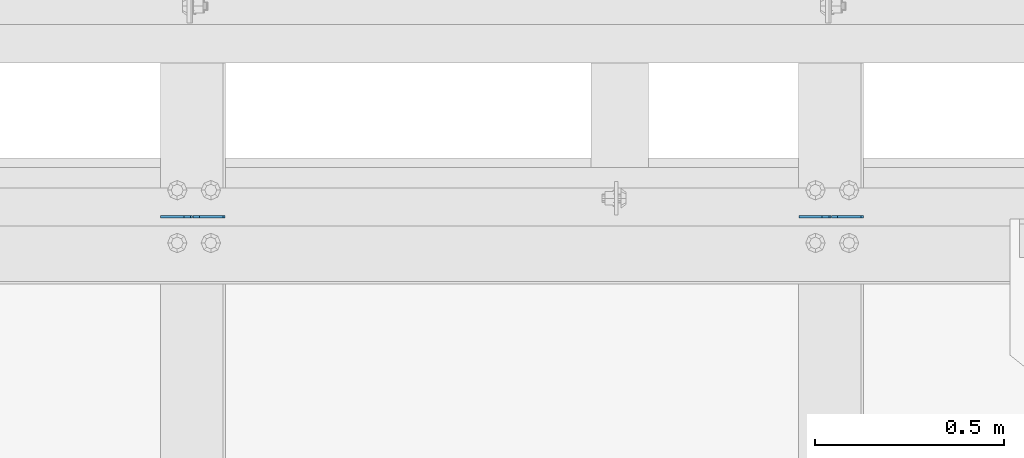
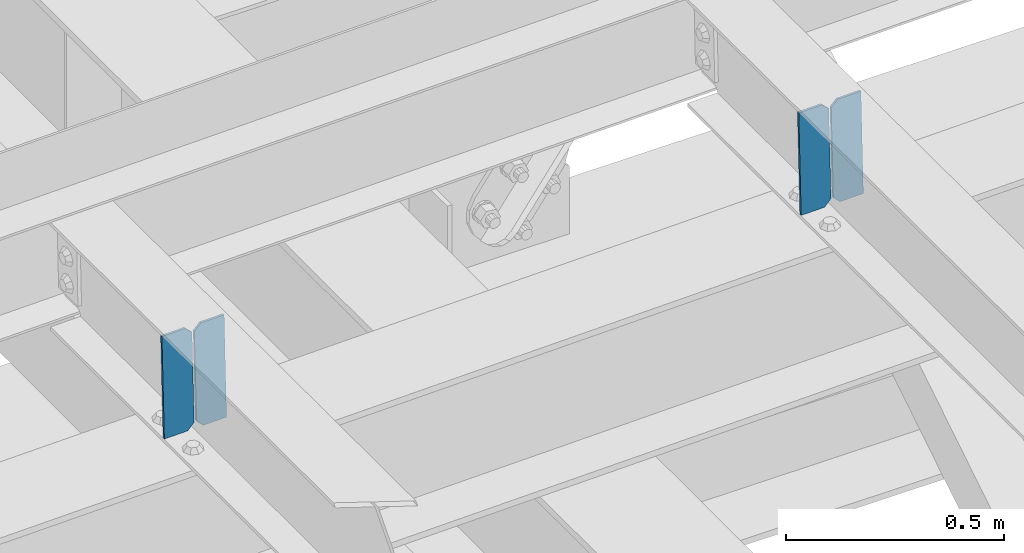
# One storey, part 3511 of 3843: 4 plates, 2 elements without a shape of their own.
"""IFC2X3 building model written with IfcOpenShell, lengths in millimetres."""

from ifc_helpers import new_model, si_unit, frame, origin_with_axes, place, context, subcontext, project, spatial, faceted_brep, material, type_object, element, aggregate, save


model = new_model("IFC2X3")

# Units and contexts
model_context = context("Model", 3, precision=1e-05, world=origin_with_axes())
body_context = subcontext(model_context, "Body", "Model", "MODEL_VIEW")
ifc_project = project(units=[si_unit("LENGTHUNIT", "METRE", prefix="MILLI"), si_unit("AREAUNIT", "SQUARE_METRE"), si_unit("VOLUMEUNIT", "CUBIC_METRE"), si_unit("MASSUNIT", "GRAM", prefix="KILO"), si_unit("TIMEUNIT", "SECOND"), si_unit("PLANEANGLEUNIT", "RADIAN"), si_unit("SOLIDANGLEUNIT", "STERADIAN"), si_unit("THERMODYNAMICTEMPERATUREUNIT", "DEGREE_CELSIUS"), si_unit("LUMINOUSINTENSITYUNIT", "LUMEN")], contexts=[model_context])

# Site, building, storey
site_placement = place(None, origin_with_axes())
site = spatial("IfcSite", under=ifc_project, at=site_placement, CompositionType="ELEMENT")
building_placement = place(site_placement, origin_with_axes())
building = spatial("IfcBuilding", under=site, at=building_placement, Name="Undefined", CompositionType="ELEMENT")
storey_placement = place(building_placement, origin_with_axes())
storey = spatial("IfcBuildingStorey", under=building, at=storey_placement, Name="Undefined", CompositionType="ELEMENT", Elevation=0.0)

# Assembly, plates
assembly_1_placement = place(storey_placement, origin_with_axes())
assembly_1 = element("IfcElementAssembly", 1, at=assembly_1_placement, inside=storey, Name="BEAM", AssemblyPlace="NOTDEFINED", PredefinedType="RIGID_FRAME")
ifc_material = material(Name="STEEL/A572-50")
plate_type = type_object("IfcPlateType", PredefinedType="NOTDEFINED")
plate_1_placement = place(assembly_1_placement, frame((75405.9964783259, 92213.893592184, 46252.2444582782), z_axis=(-0.021152098282546, 0.00202235899982043, 0.99977422391374), x_axis=(-0.999776269341419, -4.278700010456e-05, -0.0211520550071887)))
plate_1 = element("IfcPlate", 2, at=plate_1_placement, type_object=plate_type, material=ifc_material, Name="STIFFENER", context=body_context, shape_type="Brep", body=[
    faceted_brep([(0.0, -3.17499999999927, 0.0), (6.83940015733242e-10, -3.17499999996653, 288.924999998613), (6.54836185276508e-10, 3.17500000001746, 288.924999998591), (0.0, 3.17499999999927, 0.0), (61.9125003828667, -3.17499999997744, 288.924999998599), (61.9125003828522, 3.17500000002838, 288.924999998584), (79.3750000013097, -3.17499999997744, 271.462500380039), (79.375000001266, 3.17500000002838, 271.462500380017), (79.375000000713, -3.17499999999927, 17.4624996185448), (79.3750000006694, 3.17500000000291, 17.462499618523), (61.9125003821828, -3.17499999999563, -1.45519152283669e-11), (61.9125003821682, 3.17500000000655, -2.91038304567337e-11)], [[[0, 1, 2, 3]], [[1, 4, 5, 2]], [[4, 6, 7, 5]], [[6, 8, 9, 7]], [[8, 10, 11, 9]], [[10, 0, 3, 11]], [[5, 7, 9, 11, 3, 2]], [[10, 8, 6, 4, 1, 0]]]),
])
plate_2_placement = place(assembly_1_placement, frame((75320.2906576356, 92213.8899242925, 46250.4311983872), z_axis=(-0.021152098282546, 0.00202235899982043, 0.99977422391374), x_axis=(-0.999776269341419, -4.278700010456e-05, -0.0211520550071887)))
plate_2 = element("IfcPlate", 3, at=plate_2_placement, type_object=plate_type, material=ifc_material, Name="STIFFENER", context=body_context, shape_type="Brep", body=[
    faceted_brep([(5.82076609134674e-11, -3.17499999999927, 17.4624996185667), (6.25732354819775e-10, -3.17499999997744, 271.462500380054), (5.82076609134674e-10, 3.17500000002474, 271.462500380039), (0.0, 3.17500000000655, 17.4624996185521), (17.462499619156, -3.17499999997744, 288.924999998606), (17.4624996191269, 3.17500000002474, 288.924999998591), (79.3750000013242, -3.17500000025029, 288.924999998591), (79.3750000013097, 3.1749999997337, 288.92499999857), (79.3750000006548, -3.17500000026484, -2.18278728425503e-11), (79.3750000006403, 3.17499999969732, -2.91038304567337e-11), (17.4624996184866, -3.17500000000291, 7.27595761418343e-12), (17.462499618443, 3.17500000000291, -7.27595761418343e-12)], [[[0, 1, 2, 3]], [[1, 4, 5, 2]], [[4, 6, 7, 5]], [[6, 8, 9, 7]], [[8, 10, 11, 9]], [[10, 0, 3, 11]], [[5, 7, 9, 11, 3, 2]], [[10, 8, 6, 4, 1, 0]]]),
])
aggregate(assembly_1, [plate_1, plate_2])

assembly_2_placement = place(storey_placement, origin_with_axes())
assembly_2 = element("IfcElementAssembly", 4, at=assembly_2_placement, inside=storey, Name="BEAM", AssemblyPlace="NOTDEFINED", PredefinedType="RIGID_FRAME")
plate_3_placement = place(assembly_2_placement, frame((73716.8964783452, 92213.893592184, 46216.5084406406), z_axis=(-0.021152098282546, 0.00202235899982043, 0.99977422391374), x_axis=(-0.999776269341419, -4.278700010456e-05, -0.0211520550071887)))
plate_3 = element("IfcPlate", 5, at=plate_3_placement, type_object=plate_type, material=ifc_material, Name="STIFFENER", context=body_context, shape_type="Brep", body=[
    faceted_brep([(0.0, -3.17499999999927, 0.0), (6.83940015733242e-10, -3.17499999996653, 288.924999998613), (6.54836185276508e-10, 3.17500000001746, 288.924999998591), (0.0, 3.17499999999927, 0.0), (61.9125003828667, -3.17499999997744, 288.924999998599), (61.9125003828522, 3.17500000002838, 288.924999998584), (79.3750000013097, -3.17499999997744, 271.462500380039), (79.375000001266, 3.17500000002838, 271.462500380017), (79.375000000713, -3.17499999999927, 17.4624996185448), (79.3750000006694, 3.17500000000291, 17.462499618523), (61.9125003821828, -3.17499999999563, -1.45519152283669e-11), (61.9125003821682, 3.17500000000655, -2.91038304567337e-11)], [[[0, 1, 2, 3]], [[1, 4, 5, 2]], [[4, 6, 7, 5]], [[6, 8, 9, 7]], [[8, 10, 11, 9]], [[10, 0, 3, 11]], [[5, 7, 9, 11, 3, 2]], [[10, 8, 6, 4, 1, 0]]]),
])
plate_4_placement = place(assembly_2_placement, frame((73631.190657655, 92213.8899242925, 46214.6951807497), z_axis=(-0.021152098282546, 0.00202235899982043, 0.99977422391374), x_axis=(-0.999776269341419, -4.278700010456e-05, -0.0211520550071887)))
plate_4 = element("IfcPlate", 6, at=plate_4_placement, type_object=plate_type, material=ifc_material, Name="STIFFENER", context=body_context, shape_type="Brep", body=[
    faceted_brep([(5.82076609134674e-11, -3.17499999999927, 17.4624996185667), (6.25732354819775e-10, -3.17499999997744, 271.462500380054), (5.82076609134674e-10, 3.17500000002474, 271.462500380039), (0.0, 3.17500000000655, 17.4624996185521), (17.462499619156, -3.17499999997744, 288.924999998606), (17.4624996191269, 3.17500000002474, 288.924999998591), (79.3750000013242, -3.17500000025029, 288.924999998591), (79.3750000013097, 3.1749999997337, 288.92499999857), (79.3750000006548, -3.17500000026484, -2.18278728425503e-11), (79.3750000006403, 3.17499999969732, -2.91038304567337e-11), (17.4624996184866, -3.17500000000291, 7.27595761418343e-12), (17.462499618443, 3.17500000000291, -7.27595761418343e-12)], [[[0, 1, 2, 3]], [[1, 4, 5, 2]], [[4, 6, 7, 5]], [[6, 8, 9, 7]], [[8, 10, 11, 9]], [[10, 0, 3, 11]], [[5, 7, 9, 11, 3, 2]], [[10, 8, 6, 4, 1, 0]]]),
])
aggregate(assembly_2, [plate_3, plate_4])

save(model, "model.ifc")
